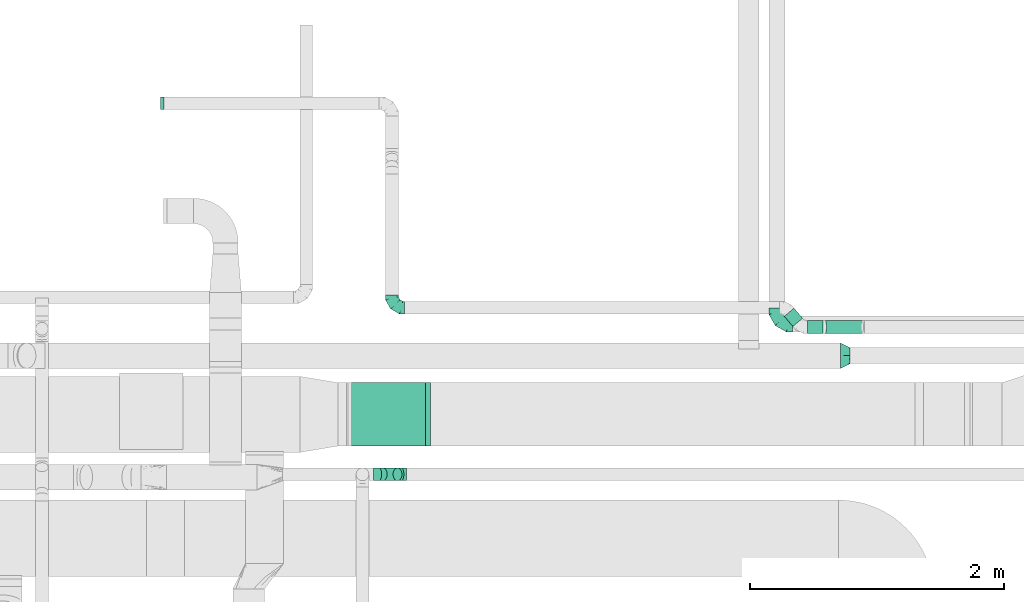
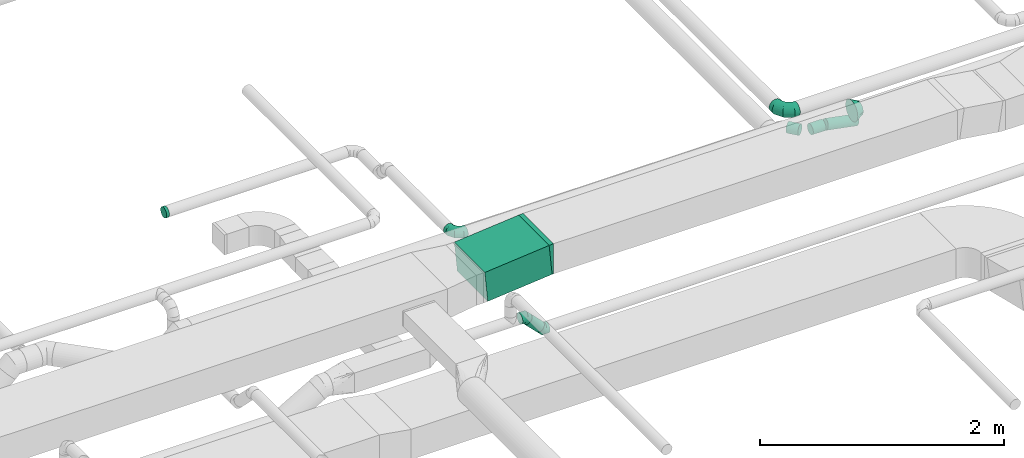
# One storey, part 44 of 60: 7 flow fittings, 5 flow segments.
"""IFC2X3 building model written with IfcOpenShell, lengths in millimetres."""

from ifc_helpers import new_model, entity, si_unit, converted_unit, derived_unit, direction, frame, frame_2d, origin, origin_2d_with_axis, place, context, subcontext, project, spatial, polyline, circle_curve, parameter, trimmed, segment, composite_curve, rectangle, circle, outline, extrude, faceted_brep, source, transform, mapped, material, type_object, type_shapes, element, save


model = new_model("IFC2X3")

# Units and contexts
model_context = context("Model", 3, precision=0.01, world=origin(), true_north=direction((6.12303176911189e-17, 1.0)))
body_context = subcontext(model_context, "Body", "Model", "MODEL_VIEW")
ifc_project = project(units=[si_unit("LENGTHUNIT", "METRE", prefix="MILLI"), si_unit("AREAUNIT", "SQUARE_METRE"), si_unit("VOLUMEUNIT", "CUBIC_METRE"), converted_unit("PLANEANGLEUNIT", "DEGREE", entity("IfcRatioMeasure", 0.0174532925199433), si_unit("PLANEANGLEUNIT", "RADIAN"), dimensions=[0, 0, 0, 0, 0, 0, 0]), si_unit("MASSUNIT", "GRAM", prefix="KILO"), derived_unit("MASSDENSITYUNIT", [(si_unit("MASSUNIT", "GRAM", prefix="KILO"), 1), (si_unit("LENGTHUNIT", "METRE"), -3)]), derived_unit("MOMENTOFINERTIAUNIT", [(si_unit("LENGTHUNIT", "METRE"), 4)]), si_unit("TIMEUNIT", "SECOND"), si_unit("FREQUENCYUNIT", "HERTZ"), si_unit("THERMODYNAMICTEMPERATUREUNIT", "DEGREE_CELSIUS"), derived_unit("THERMALTRANSMITTANCEUNIT", [(si_unit("MASSUNIT", "GRAM", prefix="KILO"), 1), (si_unit("THERMODYNAMICTEMPERATUREUNIT", "KELVIN"), -1), (si_unit("TIMEUNIT", "SECOND"), -3)]), derived_unit("VOLUMETRICFLOWRATEUNIT", [(si_unit("LENGTHUNIT", "METRE"), 3), (si_unit("TIMEUNIT", "SECOND"), -1)]), derived_unit("MASSFLOWRATEUNIT", [(si_unit("MASSUNIT", "GRAM", prefix="KILO"), 1), (si_unit("TIMEUNIT", "SECOND"), -1)]), derived_unit("ROTATIONALFREQUENCYUNIT", [(si_unit("TIMEUNIT", "SECOND"), -1)]), si_unit("ELECTRICCURRENTUNIT", "AMPERE"), si_unit("ELECTRICVOLTAGEUNIT", "VOLT"), si_unit("POWERUNIT", "WATT"), si_unit("FORCEUNIT", "NEWTON", prefix="KILO"), si_unit("ILLUMINANCEUNIT", "LUX"), si_unit("LUMINOUSFLUXUNIT", "LUMEN"), si_unit("LUMINOUSINTENSITYUNIT", "CANDELA"), derived_unit("USERDEFINED", [(si_unit("MASSUNIT", "GRAM", prefix="KILO"), -1), (si_unit("LENGTHUNIT", "METRE"), -2), (si_unit("TIMEUNIT", "SECOND"), 3), (si_unit("LUMINOUSFLUXUNIT", "LUMEN"), 1)]), derived_unit("LINEARVELOCITYUNIT", [(si_unit("LENGTHUNIT", "METRE"), 1), (si_unit("TIMEUNIT", "SECOND"), -1)]), si_unit("PRESSUREUNIT", "PASCAL"), derived_unit("USERDEFINED", [(si_unit("LENGTHUNIT", "METRE"), -2), (si_unit("MASSUNIT", "GRAM", prefix="KILO"), 1), (si_unit("TIMEUNIT", "SECOND"), -2)]), derived_unit("LINEARFORCEUNIT", [(si_unit("MASSUNIT", "GRAM", prefix="KILO"), 1), (si_unit("LENGTHUNIT", "METRE"), 1), (si_unit("TIMEUNIT", "SECOND"), -2), (si_unit("LENGTHUNIT", "METRE"), -1)]), derived_unit("PLANARFORCEUNIT", [(si_unit("MASSUNIT", "GRAM", prefix="KILO"), 1), (si_unit("LENGTHUNIT", "METRE"), 1), (si_unit("TIMEUNIT", "SECOND"), -2), (si_unit("LENGTHUNIT", "METRE"), -2)])], contexts=[model_context])

# Site, building, storey
site_placement = place(None, origin())
site = spatial("IfcSite", under=ifc_project, at=site_placement, CompositionType="ELEMENT")
building_placement = place(site_placement, origin())
building = spatial("IfcBuilding", under=site, at=building_placement, CompositionType="ELEMENT")
storey_placement = place(building_placement, frame((0.0, 0.0, 19800.0)))
storey = spatial("IfcBuildingStorey", under=building, at=storey_placement, CompositionType="ELEMENT", Elevation=19800.0)

# Flow segments
duct_segment_type_1 = type_object("IfcDuctSegmentType", PredefinedType="NOTDEFINED")
flow_segment_1_placement = place(storey_placement, frame((61125.46, 9113.95, 3421.99)))
element("IfcFlowSegment", 1, at=flow_segment_1_placement, inside=storey, type_object=duct_segment_type_1, context=body_context, shape_type="SweptSolid", body=[
    extrude(rectangle(XDim=300.0, YDim=500.000000000001, at=frame_2d((0.0, 0.0), x_axis=(0.0, 1.0))), frame((14.09, 250.0, 149.34), z_axis=(0.995579502714077, 0.0, 0.0939225945957107), x_axis=(0.0, 1.0, 0.0)), (0.0, 0.0, 1.0), 610.584725382852),
])
duct_segment_type_2 = type_object("IfcDuctSegmentType", PredefinedType="NOTDEFINED")
flow_segment_2_placement = place(storey_placement, frame((64742.32, 10000.61, 3265.78)))
element("IfcFlowSegment", 2, at=flow_segment_2_placement, inside=storey, type_object=duct_segment_type_2, context=body_context, shape_type="SweptSolid", body=[
    extrude(circle(Radius=50.0, at=origin_2d_with_axis()), frame((0.0, 51.6, 51.6), z_axis=(1.0, 0.0, 0.0), x_axis=(0.0, 1.0, 0.0)), (0.0, 0.0, 1.0), 120.362651486397),
])
flow_segment_3_placement = place(storey_placement, frame((64870.53, 10000.61, 3208.75)))
element("IfcFlowSegment", 3, at=flow_segment_3_placement, inside=storey, type_object=duct_segment_type_2, context=body_context, shape_type="SweptSolid", body=[
    extrude(circle(Radius=50.0, at=origin_2d_with_axis()), frame((302.91, 51.6, 50.7), z_axis=(-0.98200644698064, 0.0, 0.188847393650163), x_axis=(0.0, 1.0, 0.0)), (0.0, 0.0, 1.0), 297.216073901984),
])
flow_segment_4_placement = place(storey_placement, frame((64558.22, 10054.19, 3265.78)))
element("IfcFlowSegment", 4, at=flow_segment_4_placement, inside=storey, type_object=duct_segment_type_2, context=body_context, shape_type="SweptSolid", body=[
    extrude(circle(Radius=50.0, at=origin_2d_with_axis()), frame((39.9, 114.29, 51.6), z_axis=(0.642787609686425, -0.766044443119074, 0.0), x_axis=(0.766044443119074, 0.642787609686425, 0.0)), (0.0, 0.0, 1.0), 105.161758462187),
])
flow_segment_5_placement = place(storey_placement, frame((61361.53, 8840.3, 3142.34)))
element("IfcFlowSegment", 5, at=flow_segment_5_placement, inside=storey, type_object=duct_segment_type_2, context=body_context, shape_type="SweptSolid", body=[
    extrude(circle(Radius=50.0, at=origin_2d_with_axis()), frame((36.95, 51.6, 153.37), z_axis=(0.707106781186548, 0.0, -0.707106781186548), x_axis=(0.0, 1.0, 0.0)), (0.0, 0.0, 1.0), 164.64466094072),
])

# Flow fittings
ifc_material = material()
duct_fitting_type_1 = type_object("IfcDuctFittingType", PredefinedType="NOTDEFINED", material=ifc_material)
shared_shape_1 = source(origin(), body_context, "Body", "Brep", [
    faceted_brep([(-100.0, 0.0, -50.0), (-100.0, -12.94, -48.3), (-100.0, -25.0, -43.3), (-100.0, -35.36, -35.36), (-100.0, -43.3, -25.0), (-100.0, -48.3, -12.94), (-100.0, -50.0, 0.0), (-100.0, -48.3, 12.94), (-100.0, -43.3, 25.0), (-100.0, -35.36, 35.36), (-100.0, -25.0, 43.3), (-100.0, -12.94, 48.3), (-100.0, 0.0, 50.0), (-100.0, 12.94, 48.3), (-100.0, 25.0, 43.3), (-100.0, 35.36, 35.36), (-100.0, 43.3, 25.0), (-100.0, 48.3, 12.94), (-100.0, 50.0, 0.0), (-100.0, 48.3, -12.94), (-100.0, 43.3, -25.0), (-100.0, 35.36, -35.36), (-100.0, 25.0, -43.3), (-100.0, 12.94, -48.3), (-76.67, 12.94, 48.3), (-79.9, 25.0, 43.3), (-73.21, 0.0, 50.0), (-82.68, 35.36, 35.36), (-86.15, 48.3, 12.94), (-86.6, 50.0, 0.0), (-84.81, 43.3, 25.0), (-84.81, 43.3, -25.0), (-82.68, 35.36, -35.36), (-86.15, 48.3, -12.94), (-76.67, 12.94, -48.3), (-73.21, 0.0, -50.0), (-79.9, 25.0, -43.3), (-69.74, -12.94, -48.3), (-66.51, -25.0, -43.3), (-63.73, -35.36, -35.36), (-61.6, -43.3, -25.0), (-60.26, -48.3, -12.94), (-59.81, -50.0, 0.0), (-60.26, -48.3, 12.94), (-61.6, -43.3, 25.0), (-63.73, -35.36, 35.36), (-66.51, -25.0, 43.3), (-69.74, -12.94, 48.3), (-36.27, 36.27, 48.3), (-45.1, 45.1, 43.3), (-26.79, 26.79, 50.0), (-52.68, 52.68, 35.36), (-58.49, 58.49, 25.0), (-62.15, 62.15, 12.94), (-63.4, 63.4, 0.0), (-62.15, 62.15, -12.94), (-58.49, 58.49, -25.0), (-52.68, 52.68, -35.36), (-36.27, 36.27, -48.3), (-26.79, 26.79, -50.0), (-45.1, 45.1, -43.3), (-17.32, 17.32, -48.3), (-8.49, 8.49, -43.3), (-0.91, 0.91, -35.36), (4.9, -4.9, -25.0), (8.56, -8.56, -12.94), (9.81, -9.81, 0.0), (8.56, -8.56, 12.94), (4.9, -4.9, 25.0), (-0.91, 0.91, 35.36), (-8.49, 8.49, 43.3), (-17.32, 17.32, 48.3), (-12.94, 76.67, 48.3), (-25.0, 79.9, 43.3), (0.0, 73.21, 50.0), (-35.36, 82.68, 35.36), (-43.3, 84.81, 25.0), (-48.3, 86.15, 12.94), (-50.0, 86.6, 0.0), (-48.3, 86.15, -12.94), (-43.3, 84.81, -25.0), (-35.36, 82.68, -35.36), (-12.94, 76.67, -48.3), (0.0, 73.21, -50.0), (-25.0, 79.9, -43.3), (12.94, 69.74, -48.3), (25.0, 66.51, -43.3), (35.36, 63.73, -35.36), (43.3, 61.6, -25.0), (48.3, 60.26, -12.94), (50.0, 59.81, 0.0), (48.3, 60.26, 12.94), (43.3, 61.6, 25.0), (35.36, 63.73, 35.36), (25.0, 66.51, 43.3), (12.94, 69.74, 48.3), (-12.94, 100.0, -48.3), (-25.0, 100.0, -43.3), (-35.36, 100.0, -35.36), (-43.3, 100.0, -25.0), (-48.3, 100.0, -12.94), (-50.0, 100.0, 0.0), (-48.3, 100.0, 12.94), (-43.3, 100.0, 25.0), (-35.36, 100.0, 35.36), (-25.0, 100.0, 43.3), (-12.94, 100.0, 48.3), (0.0, 100.0, 50.0), (12.94, 100.0, 48.3), (25.0, 100.0, 43.3), (35.36, 100.0, 35.36), (43.3, 100.0, 25.0), (48.3, 100.0, 12.94), (50.0, 100.0, 0.0), (48.3, 100.0, -12.94), (43.3, 100.0, -25.0), (35.36, 100.0, -35.36), (25.0, 100.0, -43.3), (12.94, 100.0, -48.3), (0.0, 100.0, -50.0)], [[[0, 1, 2, 3, 4, 5, 6, 7, 8, 9, 10, 11, 12, 13, 14, 15, 16, 17, 18, 19, 20, 21, 22, 23]], [[24, 25, 14, 13]], [[26, 24, 13, 12]], [[14, 25, 27, 15]], [[28, 29, 18, 17]], [[30, 28, 17, 16]], [[15, 27, 30, 16]], [[20, 31, 32, 21]], [[33, 31, 20, 19]], [[18, 29, 33, 19]], [[34, 35, 0, 23]], [[36, 34, 23, 22]], [[32, 36, 22, 21]], [[2, 1, 37, 38]], [[3, 2, 38, 39]], [[0, 35, 37, 1]], [[5, 4, 40, 41]], [[6, 5, 41, 42]], [[3, 39, 40, 4]], [[6, 42, 43, 7]], [[7, 43, 44, 8]], [[8, 44, 45, 9]], [[10, 46, 47, 11]], [[11, 47, 26, 12]], [[10, 9, 45, 46]], [[48, 49, 25, 24]], [[50, 48, 24, 26]], [[27, 25, 49, 51]], [[52, 53, 28, 30]], [[51, 52, 30, 27]], [[29, 28, 53, 54]], [[55, 56, 31, 33]], [[54, 55, 33, 29]], [[57, 32, 31, 56]], [[58, 59, 35, 34]], [[60, 58, 34, 36]], [[57, 60, 36, 32]], [[37, 35, 59, 61]], [[38, 37, 61, 62]], [[39, 38, 62, 63]], [[41, 40, 64, 65]], [[42, 41, 65, 66]], [[63, 64, 40, 39]], [[43, 42, 66, 67]], [[44, 43, 67, 68]], [[68, 69, 45, 44]], [[46, 45, 69, 70]], [[47, 46, 70, 71]], [[26, 47, 71, 50]], [[72, 73, 49, 48]], [[74, 72, 48, 50]], [[51, 49, 73, 75]], [[76, 77, 53, 52]], [[75, 76, 52, 51]], [[54, 53, 77, 78]], [[79, 80, 56, 55]], [[78, 79, 55, 54]], [[81, 57, 56, 80]], [[82, 83, 59, 58]], [[84, 82, 58, 60]], [[81, 84, 60, 57]], [[61, 59, 83, 85]], [[62, 61, 85, 86]], [[63, 62, 86, 87]], [[65, 64, 88, 89]], [[66, 65, 89, 90]], [[87, 88, 64, 63]], [[67, 66, 90, 91]], [[68, 67, 91, 92]], [[92, 93, 69, 68]], [[70, 69, 93, 94]], [[71, 70, 94, 95]], [[50, 71, 95, 74]], [[96, 97, 98, 99, 100, 101, 102, 103, 104, 105, 106, 107, 108, 109, 110, 111, 112, 113, 114, 115, 116, 117, 118, 119]], [[72, 74, 107, 106]], [[73, 72, 106, 105]], [[75, 73, 105, 104]], [[77, 76, 103, 102]], [[78, 77, 102, 101]], [[75, 104, 103, 76]], [[78, 101, 100, 79]], [[79, 100, 99, 80]], [[80, 99, 98, 81]], [[96, 119, 83, 82]], [[97, 96, 82, 84]], [[84, 81, 98, 97]], [[83, 119, 118, 85]], [[85, 118, 117, 86]], [[86, 117, 116, 87]], [[88, 115, 114, 89]], [[89, 114, 113, 90]], [[87, 116, 115, 88]], [[91, 90, 113, 112]], [[92, 91, 112, 111]], [[93, 92, 111, 110]], [[95, 94, 109, 108]], [[74, 95, 108, 107]], [[110, 109, 94, 93]]]),
])
type_shapes(duct_fitting_type_1, [shared_shape_1])
flow_fitting_1_placement = place(storey_placement, frame((61470.8, 10204.2, 3317.38), z_axis=(0.0, 0.0, 1.0), x_axis=(0.0, -1.0, 0.0)))
element("IfcFlowFitting", 6, at=flow_fitting_1_placement, inside=storey, type_object=duct_fitting_type_1, material=ifc_material, context=body_context, shape_type="MappedRepresentation", body=[
    mapped(shared_shape_1, transform((0.0, 0.0, 0.0), scale=1.0)),
])
duct_fitting_type_2 = type_object("IfcDuctFittingType", PredefinedType="NOTDEFINED", material=ifc_material)
shared_shape_2 = source(origin(), body_context, "Body", "Brep", [
    faceted_brep([(-125.0, 0.0, -62.5), (-125.0, -16.18, -60.37), (-125.0, -31.25, -54.13), (-125.0, -44.19, -44.19), (-125.0, -54.13, -31.25), (-125.0, -60.37, -16.18), (-125.0, -62.5, 0.0), (-125.0, -60.37, 16.18), (-125.0, -54.13, 31.25), (-125.0, -44.19, 44.19), (-125.0, -31.25, 54.13), (-125.0, -16.18, 60.37), (-125.0, 0.0, 62.5), (-125.0, 16.18, 60.37), (-125.0, 31.25, 54.13), (-125.0, 44.19, 44.19), (-125.0, 54.13, 31.25), (-125.0, 60.37, 16.18), (-125.0, 62.5, 0.0), (-125.0, 60.37, -16.18), (-125.0, 54.13, -31.25), (-125.0, 44.19, -44.19), (-125.0, 31.25, -54.13), (-125.0, 16.18, -60.37), (-95.84, 16.18, 60.37), (-99.88, 31.25, 54.13), (-91.51, 0.0, 62.5), (-103.35, 44.19, 44.19), (-107.68, 60.37, 16.18), (-108.25, 62.5, 0.0), (-106.01, 54.13, 31.25), (-106.01, 54.13, -31.25), (-103.35, 44.19, -44.19), (-107.68, 60.37, -16.18), (-95.84, 16.18, -60.37), (-91.51, 0.0, -62.5), (-99.88, 31.25, -54.13), (-87.17, -16.18, -60.37), (-83.13, -31.25, -54.13), (-79.66, -44.19, -44.19), (-77.0, -54.13, -31.25), (-75.33, -60.37, -16.18), (-74.76, -62.5, 0.0), (-75.33, -60.37, 16.18), (-77.0, -54.13, 31.25), (-79.66, -44.19, 44.19), (-83.13, -31.25, 54.13), (-87.17, -16.18, 60.37), (-45.34, 45.34, 60.37), (-56.37, 56.37, 54.13), (-33.49, 33.49, 62.5), (-65.85, 65.85, 44.19), (-73.12, 73.12, 31.25), (-77.69, 77.69, 16.18), (-79.25, 79.25, 0.0), (-77.69, 77.69, -16.18), (-73.12, 73.12, -31.25), (-65.85, 65.85, -44.19), (-45.34, 45.34, -60.37), (-33.49, 33.49, -62.5), (-56.37, 56.37, -54.13), (-21.65, 21.65, -60.37), (-10.62, 10.62, -54.13), (-1.14, 1.14, -44.19), (6.13, -6.13, -31.25), (10.7, -10.7, -16.18), (12.26, -12.26, 0.0), (10.7, -10.7, 16.18), (6.13, -6.13, 31.25), (-1.14, 1.14, 44.19), (-10.62, 10.62, 54.13), (-21.65, 21.65, 60.37), (-16.18, 95.84, 60.37), (-31.25, 99.88, 54.13), (0.0, 91.51, 62.5), (-44.19, 103.35, 44.19), (-54.13, 106.01, 31.25), (-60.37, 107.68, 16.18), (-62.5, 108.25, 0.0), (-60.37, 107.68, -16.18), (-54.13, 106.01, -31.25), (-44.19, 103.35, -44.19), (-16.18, 95.84, -60.37), (0.0, 91.51, -62.5), (-31.25, 99.88, -54.13), (16.18, 87.17, -60.37), (31.25, 83.13, -54.13), (44.19, 79.66, -44.19), (54.13, 77.0, -31.25), (60.37, 75.33, -16.18), (62.5, 74.76, 0.0), (60.37, 75.33, 16.18), (54.13, 77.0, 31.25), (44.19, 79.66, 44.19), (31.25, 83.13, 54.13), (16.18, 87.17, 60.37), (-16.18, 125.0, -60.37), (-31.25, 125.0, -54.13), (-44.19, 125.0, -44.19), (-54.13, 125.0, -31.25), (-60.37, 125.0, -16.18), (-62.5, 125.0, 0.0), (-60.37, 125.0, 16.18), (-54.13, 125.0, 31.25), (-44.19, 125.0, 44.19), (-31.25, 125.0, 54.13), (-16.18, 125.0, 60.37), (0.0, 125.0, 62.5), (16.18, 125.0, 60.37), (31.25, 125.0, 54.13), (44.19, 125.0, 44.19), (54.13, 125.0, 31.25), (60.37, 125.0, 16.18), (62.5, 125.0, 0.0), (60.37, 125.0, -16.18), (54.13, 125.0, -31.25), (44.19, 125.0, -44.19), (31.25, 125.0, -54.13), (16.18, 125.0, -60.37), (0.0, 125.0, -62.5)], [[[0, 1, 2, 3, 4, 5, 6, 7, 8, 9, 10, 11, 12, 13, 14, 15, 16, 17, 18, 19, 20, 21, 22, 23]], [[24, 25, 14, 13]], [[26, 24, 13, 12]], [[14, 25, 27, 15]], [[28, 29, 18, 17]], [[30, 28, 17, 16]], [[15, 27, 30, 16]], [[20, 31, 32, 21]], [[33, 31, 20, 19]], [[18, 29, 33, 19]], [[34, 35, 0, 23]], [[36, 34, 23, 22]], [[21, 32, 36, 22]], [[1, 0, 35, 37]], [[2, 1, 37, 38]], [[38, 39, 3, 2]], [[5, 4, 40, 41]], [[6, 5, 41, 42]], [[39, 40, 4, 3]], [[6, 42, 43, 7]], [[7, 43, 44, 8]], [[45, 9, 8, 44]], [[9, 45, 46, 10]], [[10, 46, 47, 11]], [[26, 12, 11, 47]], [[48, 49, 25, 24]], [[50, 48, 24, 26]], [[27, 25, 49, 51]], [[52, 53, 28, 30]], [[51, 52, 30, 27]], [[29, 28, 53, 54]], [[55, 56, 31, 33]], [[54, 55, 33, 29]], [[57, 32, 31, 56]], [[58, 59, 35, 34]], [[60, 58, 34, 36]], [[57, 60, 36, 32]], [[37, 35, 59, 61]], [[38, 37, 61, 62]], [[39, 38, 62, 63]], [[41, 40, 64, 65]], [[42, 41, 65, 66]], [[63, 64, 40, 39]], [[43, 42, 66, 67]], [[44, 43, 67, 68]], [[68, 69, 45, 44]], [[46, 45, 69, 70]], [[47, 46, 70, 71]], [[26, 47, 71, 50]], [[72, 73, 49, 48]], [[74, 72, 48, 50]], [[51, 49, 73, 75]], [[76, 77, 53, 52]], [[75, 76, 52, 51]], [[54, 53, 77, 78]], [[79, 80, 56, 55]], [[78, 79, 55, 54]], [[81, 57, 56, 80]], [[82, 83, 59, 58]], [[84, 82, 58, 60]], [[81, 84, 60, 57]], [[61, 59, 83, 85]], [[62, 61, 85, 86]], [[63, 62, 86, 87]], [[65, 64, 88, 89]], [[66, 65, 89, 90]], [[87, 88, 64, 63]], [[67, 66, 90, 91]], [[68, 67, 91, 92]], [[92, 93, 69, 68]], [[70, 69, 93, 94]], [[71, 70, 94, 95]], [[50, 71, 95, 74]], [[96, 97, 98, 99, 100, 101, 102, 103, 104, 105, 106, 107, 108, 109, 110, 111, 112, 113, 114, 115, 116, 117, 118, 119]], [[72, 74, 107, 106]], [[73, 72, 106, 105]], [[75, 73, 105, 104]], [[77, 76, 103, 102]], [[78, 77, 102, 101]], [[75, 104, 103, 76]], [[78, 101, 100, 79]], [[79, 100, 99, 80]], [[80, 99, 98, 81]], [[96, 119, 83, 82]], [[97, 96, 82, 84]], [[84, 81, 98, 97]], [[83, 119, 118, 85]], [[85, 118, 117, 86]], [[116, 87, 86, 117]], [[88, 115, 114, 89]], [[89, 114, 113, 90]], [[115, 88, 87, 116]], [[91, 90, 113, 112]], [[92, 91, 112, 111]], [[111, 110, 93, 92]], [[95, 94, 109, 108]], [[74, 95, 108, 107]], [[110, 109, 94, 93]]]),
])
type_shapes(duct_fitting_type_2, [shared_shape_2])
flow_fitting_2_placement = place(storey_placement, frame((64501.09, 10075.43, 3550.0), z_axis=(0.0, 0.0, 1.0), x_axis=(0.0, -1.0, 0.0)))
element("IfcFlowFitting", 7, at=flow_fitting_2_placement, inside=storey, type_object=duct_fitting_type_2, material=ifc_material, context=body_context, shape_type="MappedRepresentation", body=[
    mapped(shared_shape_2, transform((0.0, 0.0, 0.0), scale=1.0)),
])
duct_fitting_type_3 = type_object("IfcDuctFittingType", PredefinedType="NOTDEFINED", material=ifc_material)
shared_shape_3 = source(origin(), body_context, "Body", "Brep", [
    faceted_brep([(-41.42, 0.0, -50.0), (-41.42, -12.94, -48.3), (-41.42, -25.0, -43.3), (-41.42, -35.36, -35.36), (-41.42, -43.3, -25.0), (-41.42, -48.3, -12.94), (-41.42, -50.0, 0.0), (-41.42, -48.3, 12.94), (-41.42, -43.3, 25.0), (-41.42, -35.36, 35.36), (-41.42, -25.0, 43.3), (-41.42, -12.94, 48.3), (-41.42, 0.0, 50.0), (-41.42, 12.94, 48.3), (-41.42, 25.0, 43.3), (-41.42, 35.36, 35.36), (-41.42, 43.3, 25.0), (-41.42, 48.3, 12.94), (-41.42, 50.0, 0.0), (-41.42, 48.3, -12.94), (-41.42, 43.3, -25.0), (-41.42, 35.36, -35.36), (-41.42, 25.0, -43.3), (-41.42, 12.94, -48.3), (-5.36, 12.94, 48.3), (-10.36, 25.0, 43.3), (0.0, 0.0, 50.0), (-14.64, 35.36, 35.36), (-20.0, 48.3, 12.94), (-20.71, 50.0, 0.0), (-17.94, 43.3, 25.0), (-17.94, 43.3, -25.0), (-14.64, 35.36, -35.36), (-20.0, 48.3, -12.94), (-5.36, 12.94, -48.3), (0.0, 0.0, -50.0), (-10.36, 25.0, -43.3), (5.36, -12.94, -48.3), (10.36, -25.0, -43.3), (14.64, -35.36, -35.36), (17.94, -43.3, -25.0), (20.0, -48.3, -12.94), (20.71, -50.0, 0.0), (20.0, -48.3, 12.94), (17.94, -43.3, 25.0), (14.64, -35.36, 35.36), (10.36, -25.0, 43.3), (5.36, -12.94, 48.3), (29.29, 29.29, 50.0), (20.14, 38.44, 48.3), (11.61, 46.97, 43.3), (4.29, 54.29, 35.36), (-1.33, 59.91, 25.0), (-4.86, 63.44, 12.94), (-6.07, 64.64, 0.0), (-4.86, 63.44, -12.94), (-1.33, 59.91, -25.0), (4.29, 54.29, -35.36), (11.61, 46.97, -43.3), (20.14, 38.44, -48.3), (29.29, 29.29, -50.0), (38.44, 20.14, -48.3), (46.97, 11.61, -43.3), (54.29, 4.29, -35.36), (59.91, -1.33, -25.0), (63.44, -4.86, -12.94), (64.64, -6.07, 0.0), (63.44, -4.86, 12.94), (59.91, -1.33, 25.0), (54.29, 4.29, 35.36), (46.97, 11.61, 43.3), (38.44, 20.14, 48.3)], [[[0, 1, 2, 3, 4, 5, 6, 7, 8, 9, 10, 11, 12, 13, 14, 15, 16, 17, 18, 19, 20, 21, 22, 23]], [[24, 25, 14, 13]], [[26, 24, 13, 12]], [[14, 25, 27, 15]], [[28, 29, 18, 17]], [[30, 28, 17, 16]], [[16, 15, 27, 30]], [[20, 31, 32, 21]], [[33, 31, 20, 19]], [[18, 29, 33, 19]], [[34, 35, 0, 23]], [[36, 34, 23, 22]], [[32, 36, 22, 21]], [[1, 0, 35, 37]], [[2, 1, 37, 38]], [[38, 39, 3, 2]], [[5, 4, 40, 41]], [[6, 5, 41, 42]], [[39, 40, 4, 3]], [[6, 42, 43, 7]], [[7, 43, 44, 8]], [[8, 44, 45, 9]], [[9, 45, 46, 10]], [[10, 46, 47, 11]], [[26, 12, 11, 47]], [[24, 26, 48, 49]], [[25, 24, 49, 50]], [[27, 25, 50, 51]], [[28, 30, 52, 53]], [[29, 28, 53, 54]], [[27, 51, 52, 30]], [[29, 54, 55, 33]], [[33, 55, 56, 31]], [[31, 56, 57, 32]], [[36, 58, 59, 34]], [[34, 59, 60, 35]], [[36, 32, 57, 58]], [[61, 62, 38, 37]], [[60, 61, 37, 35]], [[63, 39, 38, 62]], [[40, 64, 65, 41]], [[41, 65, 66, 42]], [[64, 40, 39, 63]], [[43, 42, 66, 67]], [[44, 43, 67, 68]], [[68, 69, 45, 44]], [[47, 46, 70, 71]], [[26, 47, 71, 48]], [[69, 70, 46, 45]], [[59, 58, 57, 56, 55, 54, 53, 52, 51, 50, 49, 48, 71, 70, 69, 68, 67, 66, 65, 64, 63, 62, 61, 60]]]),
])
type_shapes(duct_fitting_type_3, [shared_shape_3])
for number, where, z_axis, x_axis in (
    (8, (61544.19, 8891.89, 3150.0), (0.0, 1.0, 0.0), (-1.0, 0.0, 0.0)),
    (9, (61369.19, 8891.89, 3325.0), (0.0, -1.0, 0.0), (-0.707106781186469, 0.0, 0.707106781186626)),
):
    element("IfcFlowFitting", number, at=place(storey_placement, frame(where, z_axis=z_axis, x_axis=x_axis)), inside=storey, type_object=duct_fitting_type_3, material=ifc_material, context=body_context, shape_type="MappedRepresentation", body=[
        mapped(shared_shape_3, transform((0.0, 0.0, 0.0), scale=1.0)),
    ])
duct_fitting_type_4 = type_object("IfcDuctFittingType", PredefinedType="NOTDEFINED", material=ifc_material)
shared_shape_4 = source(origin(), body_context, "Body", "Brep", [
    faceted_brep([(75.0, -57.74, 23.92), (75.0, -60.12, 11.96), (75.0, -62.5, 0.0), (75.0, -60.12, -11.96), (75.0, -57.74, -23.92), (75.0, -50.97, -34.06), (75.0, -44.19, -44.19), (75.0, -34.06, -50.97), (75.0, -23.92, -57.74), (75.0, -11.96, -60.12), (75.0, 0.0, -62.5), (75.0, 11.96, -60.12), (75.0, 23.92, -57.74), (75.0, 34.06, -50.97), (75.0, 44.19, -44.19), (75.0, 50.97, -34.06), (75.0, 57.74, -23.92), (75.0, 60.12, -11.96), (75.0, 62.5, 0.0), (75.0, 60.12, 11.96), (75.0, 57.74, 23.92), (75.0, 50.97, 34.06), (75.0, 44.19, 44.19), (75.0, 34.06, 50.97), (75.0, 23.92, 57.74), (75.0, 11.96, 60.12), (75.0, 0.0, 62.5), (75.0, -11.96, 60.12), (75.0, -23.92, 57.74), (75.0, -34.06, 50.97), (75.0, -44.19, 44.19), (75.0, -50.97, 34.06), (0.0, -100.0, 0.0), (0.0, -95.11, 30.9), (0.0, -80.9, 58.78), (0.0, -58.78, 80.9), (0.0, -30.9, 95.11), (0.0, 0.0, 100.0), (0.0, 30.9, 95.11), (0.0, 58.78, 80.9), (0.0, 80.9, 58.78), (0.0, 95.11, 30.9), (0.0, 100.0, 0.0), (0.0, 95.11, -30.9), (0.0, 80.9, -58.78), (0.0, 58.78, -80.9), (0.0, 30.9, -95.11), (0.0, 0.0, -100.0), (0.0, -30.9, -95.11), (0.0, -58.78, -80.9), (0.0, -80.9, -58.78), (0.0, -95.11, -30.9)], [[[0, 1, 2, 3, 4, 5, 6, 7, 8, 9, 10, 11, 12, 13, 14, 15, 16, 17, 18, 19, 20, 21, 22, 23, 24, 25, 26, 27, 28, 29, 30, 31]], [[32, 33, 34, 35, 36, 37, 38, 39, 40, 41, 42, 43, 44, 45, 46, 47, 48, 49, 50, 51]], [[37, 25, 38]], [[41, 20, 19]], [[24, 39, 38]], [[40, 22, 21, 20]], [[23, 22, 39, 24]], [[18, 42, 19]], [[25, 24, 38]], [[40, 20, 41]], [[19, 42, 41]], [[25, 37, 26]], [[22, 40, 39]], [[32, 1, 33]], [[36, 28, 27]], [[0, 34, 33]], [[35, 30, 29, 28]], [[31, 30, 34, 0]], [[26, 37, 27]], [[1, 0, 33]], [[35, 28, 36]], [[27, 37, 36]], [[1, 32, 2]], [[30, 35, 34]], [[47, 9, 48]], [[51, 4, 3]], [[8, 49, 48]], [[50, 6, 5, 4]], [[7, 6, 49, 8]], [[2, 32, 3]], [[9, 8, 48]], [[50, 4, 51]], [[3, 32, 51]], [[9, 47, 10]], [[6, 50, 49]], [[42, 17, 43]], [[46, 12, 11]], [[16, 44, 43]], [[45, 14, 13, 12]], [[15, 14, 44, 16]], [[10, 47, 11]], [[17, 16, 43]], [[45, 12, 46]], [[11, 47, 46]], [[17, 42, 18]], [[14, 45, 44]]]),
])
type_shapes(duct_fitting_type_4, [shared_shape_4])
flow_fitting_3_placement = place(storey_placement, frame((65002.9, 9826.0, 3550.0)))
element("IfcFlowFitting", 10, at=flow_fitting_3_placement, inside=storey, type_object=duct_fitting_type_4, material=ifc_material, context=body_context, shape_type="MappedRepresentation", body=[
    mapped(shared_shape_4, transform((0.0, 0.0, 0.0), scale=1.0)),
])
duct_fitting_type_5 = type_object("IfcDuctFittingType", PredefinedType="NOTDEFINED", material=ifc_material)
shared_shape_5 = source(origin(), body_context, "Body", "Brep", [
    faceted_brep([(20.0, 12.94, -48.3), (20.0, 25.0, -43.3), (20.0, 35.36, -35.36), (20.0, 43.3, -25.0), (20.0, 48.3, -12.94), (20.0, 50.0, 0.0), (20.0, 48.3, 12.94), (20.0, 43.3, 25.0), (20.0, 35.36, 35.36), (20.0, 25.0, 43.3), (20.0, 12.94, 48.3), (20.0, 0.0, 50.0), (20.0, -12.94, 48.3), (20.0, -25.0, 43.3), (20.0, -35.36, 35.36), (20.0, -43.3, 25.0), (20.0, -48.3, 12.94), (20.0, -50.0, 0.0), (20.0, -48.3, -12.94), (20.0, -43.3, -25.0), (20.0, -35.36, -35.36), (20.0, -25.0, -43.3), (20.0, -12.94, -48.3), (20.0, 0.0, -50.0), (0.0, 0.0, 50.0), (0.0, 12.94, 48.3), (-6.1, 12.94, 48.3), (-6.1, 0.0, 50.0), (0.0, 25.0, 43.3), (-6.1, 25.0, 43.3), (0.0, 35.36, 35.36), (-6.1, 35.36, 35.36), (0.0, 43.3, 25.0), (0.0, 48.3, 12.94), (-6.1, 48.3, 12.94), (-6.1, 43.3, 25.0), (0.0, 50.0, 0.0), (-6.1, 50.0, 0.0), (0.0, 48.3, -12.94), (-6.1, 48.3, -12.94), (0.0, 43.3, -25.0), (-6.1, 43.3, -25.0), (0.0, 35.36, -35.36), (-6.1, 35.36, -35.36), (0.0, 25.0, -43.3), (0.0, 12.94, -48.3), (-6.1, 12.94, -48.3), (-6.1, 25.0, -43.3), (0.0, 0.0, -50.0), (-6.1, 0.0, -50.0), (0.0, -12.94, -48.3), (-6.1, -12.94, -48.3), (0.0, -25.0, -43.3), (-6.1, -25.0, -43.3), (0.0, -35.36, -35.36), (-6.1, -35.36, -35.36), (0.0, -43.3, -25.0), (0.0, -48.3, -12.94), (-6.1, -48.3, -12.94), (-6.1, -43.3, -25.0), (0.0, -50.0, 0.0), (-6.1, -50.0, 0.0), (0.0, -48.3, 12.94), (-6.1, -48.3, 12.94), (0.0, -43.3, 25.0), (-6.1, -43.3, 25.0), (0.0, -35.36, 35.36), (-6.1, -35.36, 35.36), (0.0, -25.0, 43.3), (0.0, -12.94, 48.3), (-6.1, -12.94, 48.3), (-6.1, -25.0, 43.3)], [[[0, 1, 2, 3, 4, 5, 6, 7, 8, 9, 10, 11, 12, 13, 14, 15, 16, 17, 18, 19, 20, 21, 22, 23]], [[24, 11, 10, 25, 26, 27]], [[25, 10, 9, 28, 29, 26]], [[28, 9, 8, 30, 31, 29]], [[32, 7, 6, 33, 34, 35]], [[33, 6, 5, 36, 37, 34]], [[30, 8, 7, 32, 35, 31]], [[36, 5, 4, 38, 39, 37]], [[38, 4, 3, 40, 41, 39]], [[40, 3, 2, 42, 43, 41]], [[44, 1, 0, 45, 46, 47]], [[45, 0, 23, 48, 49, 46]], [[42, 2, 1, 44, 47, 43]], [[48, 23, 22, 50, 51, 49]], [[50, 22, 21, 52, 53, 51]], [[52, 21, 20, 54, 55, 53]], [[56, 19, 18, 57, 58, 59]], [[57, 18, 17, 60, 61, 58]], [[54, 20, 19, 56, 59, 55]], [[60, 17, 16, 62, 63, 61]], [[62, 16, 15, 64, 65, 63]], [[64, 15, 14, 66, 67, 65]], [[68, 13, 12, 69, 70, 71]], [[69, 12, 11, 24, 27, 70]], [[66, 14, 13, 68, 71, 67]], [[49, 51, 53, 55, 59, 58, 61, 63, 65, 67, 71, 70, 27, 26, 29, 31, 35, 34, 37, 39, 41, 43, 47, 46]]]),
])
type_shapes(duct_fitting_type_5, [shared_shape_5])
flow_fitting_4_placement = place(storey_placement, frame((59655.69, 11814.2, 3199.99), z_axis=(0.0, -1.0, 0.0), x_axis=(1.0, 0.0, 0.0)))
element("IfcFlowFitting", 11, at=flow_fitting_4_placement, inside=storey, type_object=duct_fitting_type_5, material=ifc_material, context=body_context, shape_type="MappedRepresentation", body=[
    mapped(shared_shape_5, transform((0.0, 0.0, 0.0), scale=1.0)),
])
duct_fitting_type_6 = type_object("IfcDuctFittingType", PredefinedType="NOTDEFINED", material=ifc_material)
shared_shape_6 = source(origin(), body_context, "Body", "SweptSolid", [
    extrude(outline(composite_curve([segment(polyline([(-150.66, -14.09), (149.34, -14.09)]), True, "CONTINUOUS"), segment(trimmed(circle_curve(frame_2d((299.34, -14.09), x_axis=(-0.99557950271408, 0.093922594595683)), 150.0), [parameter(0.0)], [parameter(5.38931175997428)], True, "PARAMETER"), False, "CONTINUOUS"), segment(polyline([(150.0, 0.0), (-148.67, 28.18)]), True, "CONTINUOUS"), segment(trimmed(circle_curve(frame_2d((299.34, -14.09), x_axis=(-0.99557950271408, 0.093922594595683)), 450.0), [parameter(0.0)], [parameter(5.38931175997428)], True, "PARAMETER"), True, "CONTINUOUS")], self_intersect=False)), frame((-0.03, 0.66, -250.0), z_axis=(0.0, 0.0, 1.0), x_axis=(-0.0939225945956836, 0.99557950271408, 0.0)), (0.0, 0.0, 1.0), 500.0),
])
type_shapes(duct_fitting_type_6, [shared_shape_6])
flow_fitting_5_placement = place(storey_placement, frame((61761.49, 9363.95, 3630.0), z_axis=(0.0, 1.0, 0.0), x_axis=(0.995579502714078, 0.0, 0.0939225945957081)))
element("IfcFlowFitting", 12, at=flow_fitting_5_placement, inside=storey, type_object=duct_fitting_type_6, material=ifc_material, context=body_context, shape_type="MappedRepresentation", body=[
    mapped(shared_shape_6, transform((0.0, 0.0, 0.0), scale=1.0)),
])

save(model, "model.ifc")
